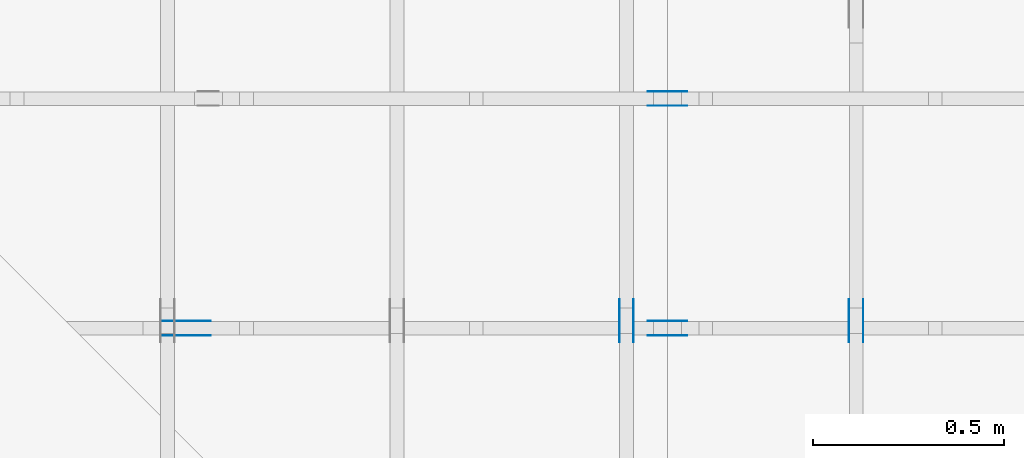
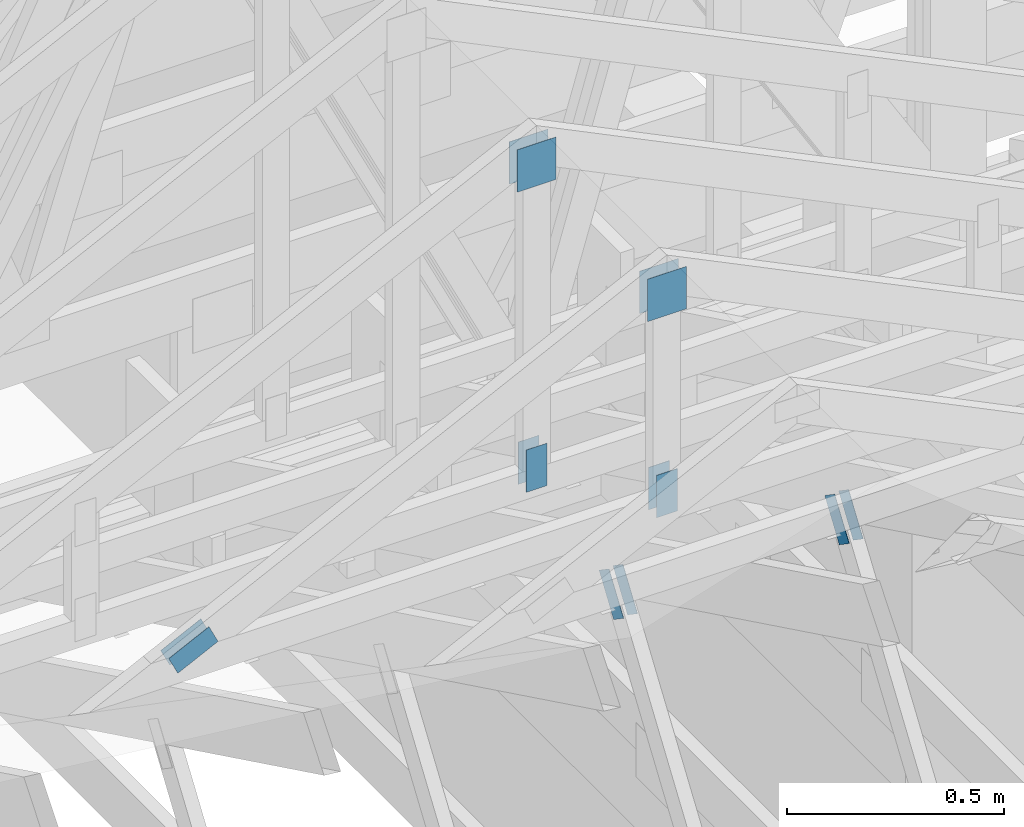
# One storey, part 88 of 159: 14 plates, 4 elements without a shape of their own.
"""IFC2X3 building model written with IfcOpenShell, lengths in millimetres."""

import ifcopenshell
import ifcopenshell.guid

model = None  # the IFC model being written
_history = None  # IfcOwnerHistory: only IFC2X3 demands one
_inside = {}  # id of a spatial element -> (the spatial element, [elements in it])
_under = {}  # id of a project, library or spatial element -> (it, [spatial elements below it])
_declared = {}  # id of a project -> (the project, [libraries it declares])
_typed = {}  # id of a type object -> (the type object, [elements of that type])
_made_of = {}  # id of a material, layer set ... -> (it, [elements and type objects made of it])


def new_model(schema):
    """Start an empty IFC model of exactly this schema.

    Asked for "IFC4X3", IfcOpenShell would pick the latest addendum, in which some entities
    have other attributes; the version numbers below select the first issue.
    IFC2X3 requires an IfcOwnerHistory on every rooted entity: one is made here for all.
    """
    global model, _history
    if schema == "IFC4X3":
        model = ifcopenshell.file(schema_version=(4, 3, 0, 0))
    else:
        model = ifcopenshell.file(schema=schema)
    _inside.clear()
    _under.clear()
    _declared.clear()
    _typed.clear()
    _made_of.clear()
    _history = None
    if model.schema == "IFC2X3":
        org = make("IfcOrganization", Name="unknown")
        user = make(
            "IfcPersonAndOrganization",
            ThePerson=make("IfcPerson", FamilyName="unknown"),
            TheOrganization=org,
        )
        app = make(
            "IfcApplication",
            ApplicationDeveloper=org,
            Version="unknown",
            ApplicationFullName="unknown",
            ApplicationIdentifier="unknown",
        )
        _history = make(
            "IfcOwnerHistory",
            OwningUser=user,
            OwningApplication=app,
            ChangeAction="ADDED",
            CreationDate=0,
        )
    return model


def make(cls, **values):
    """One entity of the class cls with the attributes given. An attribute that is None is left unset."""
    return model.create_entity(
        cls, **{name: value for name, value in values.items() if value is not None}
    )


def rooted(cls, **values):
    """An entity with a GlobalId (a new one), such as an element, a storey or a relation."""
    return make(cls, GlobalId=ifcopenshell.guid.new(), OwnerHistory=_history, **values)


def si_unit(unit_type, name, prefix=None):
    """IfcSIUnit, for example si_unit("LENGTHUNIT", "METRE", prefix="MILLI")."""
    return make("IfcSIUnit", UnitType=unit_type, Prefix=prefix, Name=name)


def assignment(units):
    """IfcUnitAssignment: the units of a project."""
    return None if units is None else make("IfcUnitAssignment", Units=units)


def point(xyz):
    """IfcCartesianPoint."""
    return None if xyz is None else make("IfcCartesianPoint", Coordinates=xyz)


def direction(xyz):
    """IfcDirection."""
    return None if xyz is None else make("IfcDirection", DirectionRatios=xyz)


def frame(location, z_axis=None, x_axis=None):
    """IfcAxis2Placement3D, a coordinate frame: its origin and axes. An axis left out is left unset."""
    return make(
        "IfcAxis2Placement3D",
        Location=point(location),
        Axis=direction(z_axis),
        RefDirection=direction(x_axis),
    )


def frame_2d(location, x_axis=None):
    """IfcAxis2Placement2D, a coordinate frame in the plane: its origin and x axis."""
    return make(
        "IfcAxis2Placement2D", Location=point(location), RefDirection=direction(x_axis)
    )


def origin():
    """The frame at (0, 0, 0) with its axes left unset."""
    return frame((0.0, 0.0, 0.0))


def origin_with_axes():
    """The frame at (0, 0, 0) with the z axis (0, 0, 1) and the x axis (1, 0, 0) written out."""
    return frame((0.0, 0.0, 0.0), z_axis=(0.0, 0.0, 1.0), x_axis=(1.0, 0.0, 0.0))


def origin_2d():
    """The frame at (0, 0) in the plane with its x axis left unset."""
    return frame_2d((0.0, 0.0))


def place(relative_to, where):
    """IfcLocalPlacement: puts the frame where relative to a parent placement (None: the world)."""
    return make(
        "IfcLocalPlacement", PlacementRelTo=relative_to, RelativePlacement=where
    )


def context(
    kind, dimensions, precision=None, world=None, true_north=None, identifier=None
):
    """IfcGeometricRepresentationContext, for example the 3D "Model" context."""
    return make(
        "IfcGeometricRepresentationContext",
        ContextIdentifier=identifier,
        ContextType=kind,
        CoordinateSpaceDimension=dimensions,
        Precision=precision,
        WorldCoordinateSystem=world,
        TrueNorth=true_north,
    )


def project(units=None, contexts=None):
    """IfcProject with its units and contexts."""
    return rooted(
        "IfcProject",
        Name="project",
        RepresentationContexts=contexts,
        UnitsInContext=assignment(units),
    )


def spatial(cls, under=None, at=None, **own):
    """A site, building, storey or space (cls), placed at a placement, below another one or the project."""
    s = rooted(cls, ObjectPlacement=at, **own)
    if under is not None:
        _under.setdefault(under.id(), (under, []))[1].append(s)
    return s


def faces_of(points, faces, orient=None, outer=None):
    """IfcFace entities. A face is a list of loops; a loop is a list of indices into points, from 0.

    orient and outer hold one flag for each loop. By default every Orientation is true, the
    first loop of a face is its IfcFaceOuterBound and the others are IfcFaceBound.
    """
    made = []
    for i, loops in enumerate(faces):
        bounds = []
        for j, loop in enumerate(loops):
            is_outer = j == 0 if outer is None else outer[i][j]
            bounds.append(
                make(
                    "IfcFaceOuterBound" if is_outer else "IfcFaceBound",
                    Bound=make("IfcPolyLoop", Polygon=[points[k] for k in loop]),
                    Orientation=True if orient is None else orient[i][j],
                )
            )
        made.append(make("IfcFace", Bounds=bounds))
    return made


def faceted_brep(points, faces, orient=None, outer=None, voids=None):
    """IfcFacetedBrep: a solid bounded by flat faces; with voids (closed shells), ...WithVoids."""
    shared = [point(p) for p in points]
    hull = make("IfcClosedShell", CfsFaces=faces_of(shared, faces, orient, outer))
    if voids is None:
        return make("IfcFacetedBrep", Outer=hull)
    return make(
        "IfcFacetedBrepWithVoids",
        Outer=hull,
        Voids=[
            make(cls, CfsFaces=faces_of(shared, fs, o, b)) for cls, fs, o, b in voids
        ],
    )


def shape(context_of_items, identifier, shape_type, items):
    """IfcShapeRepresentation: the items that make up one representation, for example the "Body"."""
    return make(
        "IfcShapeRepresentation",
        ContextOfItems=context_of_items,
        RepresentationIdentifier=identifier,
        RepresentationType=shape_type,
        Items=items,
    )


def made_of(thing, what):
    """Note that an element or type object is made of a material, layer set ...; save() writes the relation."""
    if what is not None:
        _made_of.setdefault(what.id(), (what, []))[1].append(thing)
    return thing


def element(
    cls,
    number,
    at=None,
    inside=None,
    cuts=None,
    type_object=None,
    material=None,
    context=None,
    identifier="Body",
    shape_type=None,
    held_by="IfcProductDefinitionShape",
    body=None,
    shapes=None,
    **own,
):
    """One element of the class cls, such as IfcWall. Its Tag is "e" and its number.

    at: its placement. inside: the storey or other place that contains it. cuts: it is an
    opening in that element (IfcRelVoidsElement). A single representation is given by context,
    identifier, shape_type and body (its items); several are given by shapes. held_by: the class
    of the entity that holds the representations. save() writes the other relations.
    """
    e = rooted(cls, Tag="e%d" % number, ObjectPlacement=at, **own)
    if body is not None:
        shapes = [shape(context, identifier, shape_type, body)]
    if shapes is not None:
        e.Representation = make(held_by, Representations=shapes)
    if inside is not None:
        _inside.setdefault(inside.id(), (inside, []))[1].append(e)
    if cuts is not None:
        rooted(
            "IfcRelVoidsElement", RelatingBuildingElement=cuts, RelatedOpeningElement=e
        )
    if type_object is not None:
        _typed.setdefault(type_object.id(), (type_object, []))[1].append(e)
    return made_of(e, material)


def aggregate(whole, parts):
    """IfcRelAggregates: a whole, such as a stair, and the parts it consists of."""
    return rooted("IfcRelAggregates", RelatingObject=whole, RelatedObjects=parts)


def save(model, path):
    """Write the relations noted so far, then the file.

    IfcRelAggregates (storeys below a building ...), IfcRelContainedInSpatialStructure (elements
    in a storey), IfcRelDefinesByType, IfcRelAssociatesMaterial and IfcRelDeclares: one each for
    every whole, place, type object, material and project.
    """
    for whole, parts in _under.values():
        aggregate(whole, parts)
    for where, things in _inside.values():
        rooted(
            "IfcRelContainedInSpatialStructure",
            RelatedElements=things,
            RelatingStructure=where,
        )
    for kind, things in _typed.values():
        rooted("IfcRelDefinesByType", RelatedObjects=things, RelatingType=kind)
    for what, things in _made_of.values():
        rooted("IfcRelAssociatesMaterial", RelatedObjects=things, RelatingMaterial=what)
    for by, libraries in _declared.values():
        rooted("IfcRelDeclares", RelatingContext=by, RelatedDefinitions=libraries)
    model.write(path)


model = new_model("IFC2X3")

# Units and contexts
model_context = context("Model", 3, precision=1e-05, world=origin())
plan_context = context("Plan", 2, precision=1e-05, world=origin_2d())
ifc_project = project(units=[si_unit("LENGTHUNIT", "METRE", prefix="MILLI"), si_unit("AREAUNIT", "SQUARE_METRE"), si_unit("VOLUMEUNIT", "CUBIC_METRE"), si_unit("SOLIDANGLEUNIT", "STERADIAN"), si_unit("PLANEANGLEUNIT", "RADIAN"), si_unit("MASSUNIT", "GRAM"), si_unit("TIMEUNIT", "SECOND"), si_unit("THERMODYNAMICTEMPERATUREUNIT", "DEGREE_CELSIUS"), si_unit("LUMINOUSINTENSITYUNIT", "LUMEN")], contexts=[model_context, plan_context])

# Site, building, storey
site_placement = place(None, origin_with_axes())
site = spatial("IfcSite", under=ifc_project, at=site_placement, CompositionType="ELEMENT")
building_placement = place(site_placement, origin_with_axes())
building = spatial("IfcBuilding", under=site, at=building_placement, Name="Plan 1", CompositionType="ELEMENT")
storey_placement = place(building_placement, origin_with_axes())
storey = spatial("IfcBuildingStorey", under=building, at=storey_placement, Name="Etasje 1", CompositionType="ELEMENT", Elevation=0.0)

# Assembly, plates
assembly_1_placement = place(storey_placement, frame((15075.02226140475, -699.9989301294845, 1.1021457184401395e-15), z_axis=(-1.0, 1.836909530733566e-16, 6.123031769111886e-17), x_axis=(-1.836909530733566e-16, -1.0, 0.0)))
assembly_1 = element("IfcElementAssembly", 1, at=assembly_1_placement, inside=storey, Name="T7 (103)", AssemblyPlace="FACTORY", PredefinedType="TRUSS")
plate_1_placement = place(assembly_1_placement, frame((-7430.1562647054525, 1464.8788056966719, 0.0), z_axis=(0.0, 0.0, 1.0), x_axis=(0.56424750500642, -0.8256056886274646, 0.0)))
plate_1 = element("IfcPlate", 2, at=plate_1_placement, Name="GNT100S 55x119", context=model_context, shape_type="Brep", body=[
    faceted_brep([(119.00002539657544, 54.99988487959854, 1.0), (0.0, 54.99988487959854, 1.0), (2.606205816846341e-05, 0.0, 1.0), (119.0000514586336, 0.0, 1.0), (0.0, 54.99988487959854, 0.0), (119.00002539657544, 54.99988487959854, 1.4572818720567054e-14), (119.0000514586336, 4.891776097792899e-05, 1.4572821912143256e-14), (2.606205816846341e-05, 4.891776097792899e-05, 3.191576202678868e-21), (119.0000637359608, 2.5329963114896162e-05, 1.3384479605016376e-30), (119.0000637359608, 2.5329963114957392e-05, 1.0), (6.373596079356503e-05, 2.5329963136816616e-05, 1.0), (6.373596079356503e-05, 2.5329963136755386e-05, 7.52316384526264e-37), (119.0000637359608, 55.00002532996314, 0.0), (119.0000637359608, 55.00002532996314, 1.0), (119.0000637359608, 2.5329963136755396e-05, 1.0), (119.0000637359608, 2.5329963136755396e-05, 0.0), (6.373596079356503e-05, 55.000025329964046, 0.0), (6.373596079356503e-05, 55.000025329964046, 1.0), (119.0000637359608, 55.000025329963165, 1.0), (119.0000637359608, 55.000025329963165, 2.3665827156630354e-30), (6.373596079356503e-05, 2.5329963136755396e-05, 0.0), (6.373596079362626e-05, 2.5329963136755396e-05, 1.0), (6.373596080036159e-05, 55.000025329964046, 1.0), (6.373596080030036e-05, 55.000025329964046, -4.12407052618761e-31)], [[[0, 1, 2, 3]], [[4, 5, 6, 7]], [[8, 9, 10, 11]], [[12, 13, 14, 15]], [[16, 17, 18, 19]], [[20, 21, 22, 23]]]),
])
plate_2_placement = place(assembly_1_placement, frame((-7430.1562647054525, 1464.8788056966719, -37.0), z_axis=(0.0, 0.0, 1.0), x_axis=(0.56424750500642, -0.8256056886274646, 0.0)))
plate_2 = element("IfcPlate", 3, at=plate_2_placement, Name="GNT100S 55x119", context=model_context, shape_type="Brep", body=[
    faceted_brep([(119.00002539657544, 54.99988487959854, 1.0), (0.0, 54.99988487959854, 1.0), (2.606205816846341e-05, 0.0, 1.0), (119.0000514586336, 0.0, 1.0), (0.0, 54.99988487959854, 0.0), (119.00002539657544, 54.99988487959854, 1.4572818720567054e-14), (119.0000514586336, 4.891776097792899e-05, 1.4572821912143256e-14), (2.606205816846341e-05, 4.891776097792899e-05, 3.191576202678868e-21), (119.0000637359608, 2.5329963114896162e-05, 1.3384479605016376e-30), (119.0000637359608, 2.5329963114957392e-05, 1.0), (6.373596079356503e-05, 2.5329963136816616e-05, 1.0), (6.373596079356503e-05, 2.5329963136755386e-05, 7.52316384526264e-37), (119.0000637359608, 55.00002532996314, 0.0), (119.0000637359608, 55.00002532996314, 1.0), (119.0000637359608, 2.5329963136755396e-05, 1.0), (119.0000637359608, 2.5329963136755396e-05, 0.0), (6.373596079356503e-05, 55.000025329964046, 0.0), (6.373596079356503e-05, 55.000025329964046, 1.0), (119.0000637359608, 55.000025329963165, 1.0), (119.0000637359608, 55.000025329963165, 2.3665827156630354e-30), (6.373596079356503e-05, 2.5329963136755396e-05, 0.0), (6.373596079362626e-05, 2.5329963136755396e-05, 1.0), (6.373596080036159e-05, 55.000025329964046, 1.0), (6.373596080030036e-05, 55.000025329964046, -4.12407052618761e-31)], [[[0, 1, 2, 3]], [[4, 5, 6, 7]], [[8, 9, 10, 11]], [[12, 13, 14, 15]], [[16, 17, 18, 19]], [[20, 21, 22, 23]]]),
])
aggregate(assembly_1, [plate_1, plate_2])

assembly_2_placement = place(storey_placement, frame((14475.022261404752, -699.9989301294836, 1.1021457184401395e-15), z_axis=(-1.0, 1.836909530733566e-16, 6.123031769111886e-17), x_axis=(-1.836909530733566e-16, -1.0, 0.0)))
assembly_2 = element("IfcElementAssembly", 4, at=assembly_2_placement, inside=storey, Name="T10 (102)", AssemblyPlace="FACTORY", PredefinedType="TRUSS")
plate_3_placement = place(assembly_2_placement, frame((-7430.1562647054525, 1464.8788056966719, 0.0), z_axis=(0.0, 0.0, 1.0), x_axis=(0.56424750500642, -0.8256056886274646, 0.0)))
plate_3 = element("IfcPlate", 5, at=plate_3_placement, Name="GNT100S 55x119", context=model_context, shape_type="Brep", body=[
    faceted_brep([(119.00002539657544, 54.99988487959854, 1.0), (0.0, 54.99988487959854, 1.0), (2.606205816846341e-05, 0.0, 1.0), (119.0000514586336, 0.0, 1.0), (0.0, 54.99988487959854, 0.0), (119.00002539657544, 54.99988487959854, 1.4572818720567054e-14), (119.0000514586336, 4.891776097792899e-05, 1.4572821912143256e-14), (2.606205816846341e-05, 4.891776097792899e-05, 3.191576202678868e-21), (119.0000637359608, 2.5329963114896162e-05, 1.3384479605016376e-30), (119.0000637359608, 2.5329963114957392e-05, 1.0), (6.373596079356503e-05, 2.5329963136816616e-05, 1.0), (6.373596079356503e-05, 2.5329963136755386e-05, 7.52316384526264e-37), (119.0000637359608, 55.00002532996314, 0.0), (119.0000637359608, 55.00002532996314, 1.0), (119.0000637359608, 2.5329963136755396e-05, 1.0), (119.0000637359608, 2.5329963136755396e-05, 0.0), (6.373596079356503e-05, 55.000025329964046, 0.0), (6.373596079356503e-05, 55.000025329964046, 1.0), (119.0000637359608, 55.000025329963165, 1.0), (119.0000637359608, 55.000025329963165, 2.3665827156630354e-30), (6.373596079356503e-05, 2.5329963136755396e-05, 0.0), (6.373596079362626e-05, 2.5329963136755396e-05, 1.0), (6.373596080036159e-05, 55.000025329964046, 1.0), (6.373596080030036e-05, 55.000025329964046, -4.12407052618761e-31)], [[[0, 1, 2, 3]], [[4, 5, 6, 7]], [[8, 9, 10, 11]], [[12, 13, 14, 15]], [[16, 17, 18, 19]], [[20, 21, 22, 23]]]),
])
plate_4_placement = place(assembly_2_placement, frame((-7430.1562647054525, 1464.8788056966719, -37.0), z_axis=(0.0, 0.0, 1.0), x_axis=(0.56424750500642, -0.8256056886274646, 0.0)))
plate_4 = element("IfcPlate", 6, at=plate_4_placement, Name="GNT100S 55x119", context=model_context, shape_type="Brep", body=[
    faceted_brep([(119.00002539657544, 54.99988487959854, 1.0), (0.0, 54.99988487959854, 1.0), (2.606205816846341e-05, 0.0, 1.0), (119.0000514586336, 0.0, 1.0), (0.0, 54.99988487959854, 0.0), (119.00002539657544, 54.99988487959854, 1.4572818720567054e-14), (119.0000514586336, 4.891776097792899e-05, 1.4572821912143256e-14), (2.606205816846341e-05, 4.891776097792899e-05, 3.191576202678868e-21), (119.0000637359608, 2.5329963114896162e-05, 1.3384479605016376e-30), (119.0000637359608, 2.5329963114957392e-05, 1.0), (6.373596079356503e-05, 2.5329963136816616e-05, 1.0), (6.373596079356503e-05, 2.5329963136755386e-05, 7.52316384526264e-37), (119.0000637359608, 55.00002532996314, 0.0), (119.0000637359608, 55.00002532996314, 1.0), (119.0000637359608, 2.5329963136755396e-05, 1.0), (119.0000637359608, 2.5329963136755396e-05, 0.0), (6.373596079356503e-05, 55.000025329964046, 0.0), (6.373596079356503e-05, 55.000025329964046, 1.0), (119.0000637359608, 55.000025329963165, 1.0), (119.0000637359608, 55.000025329963165, 2.3665827156630354e-30), (6.373596079356503e-05, 2.5329963136755396e-05, 0.0), (6.373596079362626e-05, 2.5329963136755396e-05, 1.0), (6.373596080036159e-05, 55.000025329964046, 1.0), (6.373596080030036e-05, 55.000025329964046, -4.12407052618761e-31)], [[[0, 1, 2, 3]], [[4, 5, 6, 7]], [[8, 9, 10, 11]], [[12, 13, 14, 15]], [[16, 17, 18, 19]], [[20, 21, 22, 23]]]),
])
aggregate(assembly_2, [plate_3, plate_4])

assembly_3_placement = place(storey_placement, frame((12446.012607049342, 7236.0000560521385, 1312.9938842936408), z_axis=(0.0, -1.0, 6.123031769111886e-17), x_axis=(1.0, 0.0, 0.0)))
assembly_3 = element("IfcElementAssembly", 7, at=assembly_3_placement, inside=storey, Name="Tr3 (84)", AssemblyPlace="FACTORY", PredefinedType="TRUSS")
plate_5_placement = place(assembly_3_placement, frame((2102.5, 1001.0410329438746, 0.0), z_axis=(0.0, 0.0, 1.0), x_axis=(6.123031769111886e-17, -1.0, 0.0)))
plate_5 = element("IfcPlate", 8, at=plate_5_placement, Name="GNT100S 103x119", context=model_context, shape_type="Brep", body=[
    faceted_brep([(119.0000173188746, 103.0, 1.0), (1.731887459754944e-05, 103.0, 1.0), (1.731887459754944e-05, 0.0, 1.0), (119.0000173188746, 0.0, 1.0), (1.731887459754944e-05, 103.0, 2.120880387321201e-21), (119.0000173188746, 103.0, 1.4572817731366677e-14), (119.0000173188746, 0.0, 1.4572817731366677e-14), (1.731887459754944e-05, 0.0, 2.120880387321201e-21), (119.0, 5.605214116800701e-05, 1.3384468320270608e-30), (119.0, 5.605214116806824e-05, 1.0), (1.1247455413666031e-32, 5.6052141189927464e-05, 1.0), (0.0, 5.6052141189866234e-05, 0.0), (119.0, 103.00005605214119, 0.0), (119.0, 103.00005605214119, 1.0), (119.0, 5.6052141189866234e-05, 1.0), (119.0, 5.6052141189866234e-05, 0.0), (0.0, 103.00005605214119, 0.0), (-3.7491518045553436e-33, 103.00005605214119, 1.0), (119.0, 103.00005605214118, 1.0), (119.0, 103.00005605214118, -7.888609052210118e-31), (6.864180824645918e-21, 5.6052141189866234e-05, -4.202959725823558e-37), (6.123718187194351e-17, 5.6052141189866234e-05, 1.0), (1.2674682626242429e-14, 103.00005605214119, 1.0), (1.261345230855131e-14, 103.00005605214119, -7.723256920343734e-31)], [[[0, 1, 2, 3]], [[4, 5, 6, 7]], [[8, 9, 10, 11]], [[12, 13, 14, 15]], [[16, 17, 18, 19]], [[20, 21, 22, 23]]]),
])
plate_6_placement = place(assembly_3_placement, frame((2102.5, 1001.0410329438746, -37.0), z_axis=(0.0, 0.0, 1.0), x_axis=(6.123031769111886e-17, -1.0, 0.0)))
plate_6 = element("IfcPlate", 9, at=plate_6_placement, Name="GNT100S 103x119", context=model_context, shape_type="Brep", body=[
    faceted_brep([(119.0000173188746, 103.0, 1.0), (1.731887459754944e-05, 103.0, 1.0), (1.731887459754944e-05, 0.0, 1.0), (119.0000173188746, 0.0, 1.0), (1.731887459754944e-05, 103.0, 2.120880387321201e-21), (119.0000173188746, 103.0, 1.4572817731366677e-14), (119.0000173188746, 0.0, 1.4572817731366677e-14), (1.731887459754944e-05, 0.0, 2.120880387321201e-21), (119.0, 5.605214116800701e-05, 1.3384468320270608e-30), (119.0, 5.605214116806824e-05, 1.0), (1.1247455413666031e-32, 5.6052141189927464e-05, 1.0), (0.0, 5.6052141189866234e-05, 0.0), (119.0, 103.00005605214119, 0.0), (119.0, 103.00005605214119, 1.0), (119.0, 5.6052141189866234e-05, 1.0), (119.0, 5.6052141189866234e-05, 0.0), (0.0, 103.00005605214119, 0.0), (-3.7491518045553436e-33, 103.00005605214119, 1.0), (119.0, 103.00005605214118, 1.0), (119.0, 103.00005605214118, -7.888609052210118e-31), (6.864180824645918e-21, 5.6052141189866234e-05, -4.202959725823558e-37), (6.123718187194351e-17, 5.6052141189866234e-05, 1.0), (1.2674682626242429e-14, 103.00005605214119, 1.0), (1.261345230855131e-14, 103.00005605214119, -7.723256920343734e-31)], [[[0, 1, 2, 3]], [[4, 5, 6, 7]], [[8, 9, 10, 11]], [[12, 13, 14, 15]], [[16, 17, 18, 19]], [[20, 21, 22, 23]]]),
])
plate_7_placement = place(assembly_3_placement, frame((2181.500056052141, 29.720829010009766, 0.0), z_axis=(0.0, 0.0, 1.0), x_axis=(-8.269481020090064e-16, 1.0, 0.0)))
plate_7 = element("IfcPlate", 10, at=plate_7_placement, Name="GNT100S 55x119", context=model_context, shape_type="Brep", body=[
    faceted_brep([(118.99999618530278, 55.00005605214119, 1.0), (4.618527782440651e-14, 55.00005605214119, 1.0), (0.0, 5.6052141189866234e-05, 1.0), (118.99999618530275, 5.6052141189866234e-05, 1.0), (4.618527782440651e-14, 55.00005605214119, 5.6558784676819955e-30), (118.99999618530278, 55.00005605214119, 1.4572815143336045e-14), (118.99999618530275, 5.6052141189866234e-05, 1.4572815143336042e-14), (0.0, 5.6052141189866234e-05, 0.0), (119.00000002048914, -2.1859223419493102e-14, 1.3384471944567084e-30), (119.00000002048914, -2.1797993101801983e-14, 1.0), (2.04891179578226e-08, 6.123031392745325e-17, 1.0), (2.04891179578226e-08, -3.763665605304859e-24, 2.304504406959537e-40), (119.00000002048914, 55.0, 1.5777218104420236e-30), (119.00000002048914, 55.0, 1.0), (119.00000002048914, 0.0, 1.0), (119.00000002048914, 0.0, 0.0), (2.04891179578226e-08, 55.0, 0.0), (2.04891179578226e-08, 55.0, 1.0), (119.00000002048911, 54.99999999999999, 1.0), (119.00000002048911, 54.99999999999999, -3.944304526105059e-31), (2.04891179578226e-08, 0.0, 0.0), (2.0489118019052918e-08, -7.498303609110687e-33, 1.0), (2.0489124754387864e-08, 55.0, 1.0), (2.0489124693157546e-08, 55.0, -4.124066985010878e-31)], [[[0, 1, 2, 3]], [[4, 5, 6, 7]], [[8, 9, 10, 11]], [[12, 13, 14, 15]], [[16, 17, 18, 19]], [[20, 21, 22, 23]]]),
])
plate_8_placement = place(assembly_3_placement, frame((2181.500056052141, 29.720829010009766, -37.0), z_axis=(0.0, 0.0, 1.0), x_axis=(-8.269481020090064e-16, 1.0, 0.0)))
plate_8 = element("IfcPlate", 11, at=plate_8_placement, Name="GNT100S 55x119", context=model_context, shape_type="Brep", body=[
    faceted_brep([(118.99999618530278, 55.00005605214119, 1.0), (4.618527782440651e-14, 55.00005605214119, 1.0), (0.0, 5.6052141189866234e-05, 1.0), (118.99999618530275, 5.6052141189866234e-05, 1.0), (4.618527782440651e-14, 55.00005605214119, 5.6558784676819955e-30), (118.99999618530278, 55.00005605214119, 1.4572815143336045e-14), (118.99999618530275, 5.6052141189866234e-05, 1.4572815143336042e-14), (0.0, 5.6052141189866234e-05, 0.0), (119.00000002048914, -2.1859223419493102e-14, 1.3384471944567084e-30), (119.00000002048914, -2.1797993101801983e-14, 1.0), (2.04891179578226e-08, 6.123031392745325e-17, 1.0), (2.04891179578226e-08, -3.763665605304859e-24, 2.304504406959537e-40), (119.00000002048914, 55.0, 1.5777218104420236e-30), (119.00000002048914, 55.0, 1.0), (119.00000002048914, 0.0, 1.0), (119.00000002048914, 0.0, 0.0), (2.04891179578226e-08, 55.0, 0.0), (2.04891179578226e-08, 55.0, 1.0), (119.00000002048911, 54.99999999999999, 1.0), (119.00000002048911, 54.99999999999999, -3.944304526105059e-31), (2.04891179578226e-08, 0.0, 0.0), (2.0489118019052918e-08, -7.498303609110687e-33, 1.0), (2.0489124754387864e-08, 55.0, 1.0), (2.0489124693157546e-08, 55.0, -4.124066985010878e-31)], [[[0, 1, 2, 3]], [[4, 5, 6, 7]], [[8, 9, 10, 11]], [[12, 13, 14, 15]], [[16, 17, 18, 19]], [[20, 21, 22, 23]]]),
])
aggregate(assembly_3, [plate_5, plate_6, plate_7, plate_8])

assembly_4_placement = place(storey_placement, frame((13046.012612936298, 6636.000050165183, 1605.6334403044173), z_axis=(0.0, -1.0, 6.123031769111886e-17), x_axis=(1.0, 0.0, 0.0)))
assembly_4 = element("IfcElementAssembly", 12, at=assembly_4_placement, inside=storey, Name="Tr4 (108)", AssemblyPlace="FACTORY", PredefinedType="TRUSS")
plate_9_placement = place(assembly_4_placement, frame((253.2841968538207, 38.42090597057235, 0.0), z_axis=(0.0, 0.0, 1.0), x_axis=(0.898794046299167, 0.4383711467890774, 0.0)))
plate_9 = element("IfcPlate", 13, at=plate_9_placement, Name="GNT100S 55x119", context=model_context, shape_type="Brep", body=[
    faceted_brep([(119.00000687542453, 55.00000532224293, 1.0), (1.0028205394974066e-06, 55.00000532224293, 1.0), (0.0, 4.3514078242878895e-06, 1.0), (119.00000420035079, 4.3514078242878895e-06, 1.0), (1.0028205394974066e-06, 55.00000532224293, 1.2280604044121083e-22), (119.00000687542453, 55.00000532224293, 1.4572816452455147e-14), (119.00000420035079, 0.0, 1.4572816124863917e-14), (0.0, 0.0, 0.0), (119.0000033913503, 2.298213821373364e-06, 2.2085824040791803e-30), (119.0000033913503, 2.2982138214345943e-06, 1.0), (3.3913503045823745e-06, 2.2982138432938177e-06, 1.0), (3.3913503045823745e-06, 2.2982138432325874e-06, 7.052966104933725e-38), (119.0000033913503, 55.00000229821387, 0.0), (119.0000033913503, 55.00000229821387, 1.0), (119.0000033913503, 2.298213857443443e-06, 1.0), (119.0000033913503, 2.298213857443443e-06, 0.0), (3.3913503045823745e-06, 55.00000229821384, 0.0), (3.3913503045823745e-06, 55.00000229821384, 1.0), (119.0000033913503, 55.000002298213865, 1.0), (119.0000033913503, 55.000002298213865, -7.888609052210118e-31), (3.391350304582375e-06, 2.2982138432325883e-06, -2.350988701644575e-38), (3.3913503046436053e-06, 2.2982138432325883e-06, 1.0), (3.39135031137894e-06, 55.00000229821384, 1.0), (3.39135031131771e-06, 55.00000229821384, -4.1240672348034275e-31)], [[[0, 1, 2, 3]], [[4, 5, 6, 7]], [[8, 9, 10, 11]], [[12, 13, 14, 15]], [[16, 17, 18, 19]], [[20, 21, 22, 23]]]),
])
plate_10_placement = place(assembly_4_placement, frame((253.2841968538207, 38.42090597057235, -37.00000000000001), z_axis=(0.0, 0.0, 1.0), x_axis=(0.898794046299167, 0.4383711467890774, 0.0)))
plate_10 = element("IfcPlate", 14, at=plate_10_placement, Name="GNT100S 55x119", context=model_context, shape_type="Brep", body=[
    faceted_brep([(119.00000687542453, 55.00000532224293, 1.0), (1.0028205394974066e-06, 55.00000532224293, 1.0), (0.0, 4.3514078242878895e-06, 1.0), (119.00000420035079, 4.3514078242878895e-06, 1.0), (1.0028205394974066e-06, 55.00000532224293, 1.2280604044121083e-22), (119.00000687542453, 55.00000532224293, 1.4572816452455147e-14), (119.00000420035079, 0.0, 1.4572816124863917e-14), (0.0, 0.0, 0.0), (119.0000033913503, 2.298213821373364e-06, 2.2085824040791803e-30), (119.0000033913503, 2.2982138214345943e-06, 1.0), (3.3913503045823745e-06, 2.2982138432938177e-06, 1.0), (3.3913503045823745e-06, 2.2982138432325874e-06, 7.052966104933725e-38), (119.0000033913503, 55.00000229821387, 0.0), (119.0000033913503, 55.00000229821387, 1.0), (119.0000033913503, 2.298213857443443e-06, 1.0), (119.0000033913503, 2.298213857443443e-06, 0.0), (3.3913503045823745e-06, 55.00000229821384, 0.0), (3.3913503045823745e-06, 55.00000229821384, 1.0), (119.0000033913503, 55.000002298213865, 1.0), (119.0000033913503, 55.000002298213865, -7.888609052210118e-31), (3.391350304582375e-06, 2.2982138432325883e-06, -2.350988701644575e-38), (3.3913503046436053e-06, 2.2982138432325883e-06, 1.0), (3.39135031137894e-06, 55.00000229821384, 1.0), (3.39135031131771e-06, 55.00000229821384, -4.1240672348034275e-31)], [[[0, 1, 2, 3]], [[4, 5, 6, 7]], [[8, 9, 10, 11]], [[12, 13, 14, 15]], [[16, 17, 18, 19]], [[20, 21, 22, 23]]]),
])
plate_11_placement = place(assembly_4_placement, frame((1502.5, 708.4014892578125, 0.0), z_axis=(0.0, 0.0, 1.0), x_axis=(6.123031769111886e-17, -1.0, 0.0)))
plate_11 = element("IfcPlate", 15, at=plate_11_placement, Name="GNT100S 103x119", context=model_context, shape_type="Brep", body=[
    faceted_brep([(119.0, 103.0, 1.0), (0.0, 103.0, 1.0), (0.0, 0.0, 1.0), (119.0, 0.0, 1.0), (0.0, 103.0, 0.0), (119.0, 103.0, 1.457281561048629e-14), (119.0, 0.0, 1.457281561048629e-14), (0.0, 0.0, 0.0), (119.00001232512295, 5.016518523549669e-05, 1.338447208185253e-30), (119.00001232512295, 5.016518523555792e-05, 1.0), (1.2325122952461243e-05, 5.0165185257417146e-05, 1.0), (1.2325122952461243e-05, 5.0165185257355915e-05, 0.0), (119.00001232512295, 103.00005016518526, 0.0), (119.00001232512295, 103.00005016518526, 1.0), (119.00001232512295, 5.0165185257355915e-05, 1.0), (119.00001232512295, 5.0165185257355915e-05, 0.0), (1.2325122952461243e-05, 103.00005016518526, 0.0), (1.2325122952461243e-05, 103.00005016518526, 1.0), (119.00001232512295, 103.00005016518524, 1.0), (119.00001232512295, 103.00005016518524, -7.888609052210118e-31), (1.232512295246125e-05, 5.0165185257355915e-05, -3.76158192263132e-37), (1.232512295252248e-05, 5.0165185257355915e-05, 1.0), (1.2325122965135925e-05, 103.00005016518526, 1.0), (1.2325122965074695e-05, 103.00005016518526, -7.72325649365961e-31)], [[[0, 1, 2, 3]], [[4, 5, 6, 7]], [[8, 9, 10, 11]], [[12, 13, 14, 15]], [[16, 17, 18, 19]], [[20, 21, 22, 23]]]),
])
plate_12_placement = place(assembly_4_placement, frame((1502.5, 708.4014892578125, -37.0), z_axis=(0.0, 0.0, 1.0), x_axis=(6.123031769111886e-17, -1.0, 0.0)))
plate_12 = element("IfcPlate", 16, at=plate_12_placement, Name="GNT100S 103x119", context=model_context, shape_type="Brep", body=[
    faceted_brep([(119.0, 103.0, 1.0), (0.0, 103.0, 1.0), (0.0, 0.0, 1.0), (119.0, 0.0, 1.0), (0.0, 103.0, 0.0), (119.0, 103.0, 1.457281561048629e-14), (119.0, 0.0, 1.457281561048629e-14), (0.0, 0.0, 0.0), (119.00001232512295, 5.016518523549669e-05, 1.338447208185253e-30), (119.00001232512295, 5.016518523555792e-05, 1.0), (1.2325122952461243e-05, 5.0165185257417146e-05, 1.0), (1.2325122952461243e-05, 5.0165185257355915e-05, 0.0), (119.00001232512295, 103.00005016518526, 0.0), (119.00001232512295, 103.00005016518526, 1.0), (119.00001232512295, 5.0165185257355915e-05, 1.0), (119.00001232512295, 5.0165185257355915e-05, 0.0), (1.2325122952461243e-05, 103.00005016518526, 0.0), (1.2325122952461243e-05, 103.00005016518526, 1.0), (119.00001232512295, 103.00005016518524, 1.0), (119.00001232512295, 103.00005016518524, -7.888609052210118e-31), (1.232512295246125e-05, 5.0165185257355915e-05, -3.76158192263132e-37), (1.232512295252248e-05, 5.0165185257355915e-05, 1.0), (1.2325122965135925e-05, 103.00005016518526, 1.0), (1.2325122965074695e-05, 103.00005016518526, -7.72325649365961e-31)], [[[0, 1, 2, 3]], [[4, 5, 6, 7]], [[8, 9, 10, 11]], [[12, 13, 14, 15]], [[16, 17, 18, 19]], [[20, 21, 22, 23]]]),
])
plate_13_placement = place(assembly_4_placement, frame((1581.5000501651853, 29.720829010009766, 0.0), z_axis=(0.0, 0.0, 1.0), x_axis=(-3.8285889215894375e-16, 1.0, 0.0)))
plate_13 = element("IfcPlate", 17, at=plate_13_placement, Name="GNT100S 55x119", context=model_context, shape_type="Brep", body=[
    faceted_brep([(118.99999618530273, 55.00005016518526, 1.0), (1.7763568394002505e-14, 55.00005016518526, 1.0), (0.0, 5.0165185257355915e-05, 1.0), (118.99999618530273, 5.0165185257355915e-05, 1.0), (1.7763568394002505e-14, 55.00005016518526, 2.175337872185383e-30), (118.99999618530273, 55.00005016518526, 1.457281514333604e-14), (118.99999618530273, 5.0165185257355915e-05, 1.457281514333604e-14), (0.0, 5.0165185257355915e-05, 0.0), (119.0000000204891, -2.1859223419493096e-14, 1.3384471944567079e-30), (119.0000000204891, -2.1797993101801977e-14, 1.0), (2.0489107299681564e-08, 6.123031392745521e-17, 1.0), (2.0489107299681564e-08, -3.763663647500774e-24, 2.304503208189876e-40), (119.0000000204891, 55.0, 1.5777218104420236e-30), (119.0000000204891, 55.0, 1.0), (119.0000000204891, 0.0, 1.0), (119.0000000204891, 0.0, 0.0), (2.0489103746967885e-08, 55.0, 0.0), (2.0489103746967885e-08, 55.0, 1.0), (119.00000002048907, 54.99999999999999, 1.0), (119.00000002048907, 54.99999999999999, -3.944304526105059e-31), (2.0489107299681564e-08, 0.0, 0.0), (2.048910736091188e-08, -7.498303609110687e-33, 1.0), (2.0489114096246827e-08, 55.0, 1.0), (2.048911403501651e-08, 55.0, -6.299404857196261e-31)], [[[0, 1, 2, 3]], [[4, 5, 6, 7]], [[8, 9, 10, 11]], [[12, 13, 14, 15]], [[16, 17, 18, 19]], [[20, 21, 22, 23]]]),
])
plate_14_placement = place(assembly_4_placement, frame((1581.5000501651853, 29.720829010009766, -37.0), z_axis=(0.0, 0.0, 1.0), x_axis=(-3.8285889215894375e-16, 1.0, 0.0)))
plate_14 = element("IfcPlate", 18, at=plate_14_placement, Name="GNT100S 55x119", context=model_context, shape_type="Brep", body=[
    faceted_brep([(118.99999618530273, 55.00005016518526, 1.0), (1.7763568394002505e-14, 55.00005016518526, 1.0), (0.0, 5.0165185257355915e-05, 1.0), (118.99999618530273, 5.0165185257355915e-05, 1.0), (1.7763568394002505e-14, 55.00005016518526, 2.175337872185383e-30), (118.99999618530273, 55.00005016518526, 1.457281514333604e-14), (118.99999618530273, 5.0165185257355915e-05, 1.457281514333604e-14), (0.0, 5.0165185257355915e-05, 0.0), (119.0000000204891, -2.1859223419493096e-14, 1.3384471944567079e-30), (119.0000000204891, -2.1797993101801977e-14, 1.0), (2.0489107299681564e-08, 6.123031392745521e-17, 1.0), (2.0489107299681564e-08, -3.763663647500774e-24, 2.304503208189876e-40), (119.0000000204891, 55.0, 1.5777218104420236e-30), (119.0000000204891, 55.0, 1.0), (119.0000000204891, 0.0, 1.0), (119.0000000204891, 0.0, 0.0), (2.0489103746967885e-08, 55.0, 0.0), (2.0489103746967885e-08, 55.0, 1.0), (119.00000002048907, 54.99999999999999, 1.0), (119.00000002048907, 54.99999999999999, -3.944304526105059e-31), (2.0489107299681564e-08, 0.0, 0.0), (2.048910736091188e-08, -7.498303609110687e-33, 1.0), (2.0489114096246827e-08, 55.0, 1.0), (2.048911403501651e-08, 55.0, -6.299404857196261e-31)], [[[0, 1, 2, 3]], [[4, 5, 6, 7]], [[8, 9, 10, 11]], [[12, 13, 14, 15]], [[16, 17, 18, 19]], [[20, 21, 22, 23]]]),
])
aggregate(assembly_4, [plate_9, plate_10, plate_11, plate_12, plate_13, plate_14])

save(model, "model.ifc")
